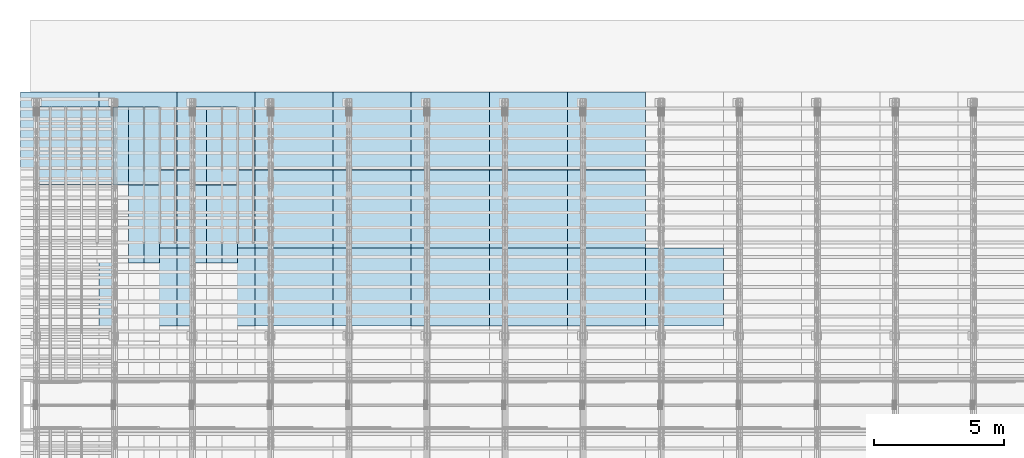
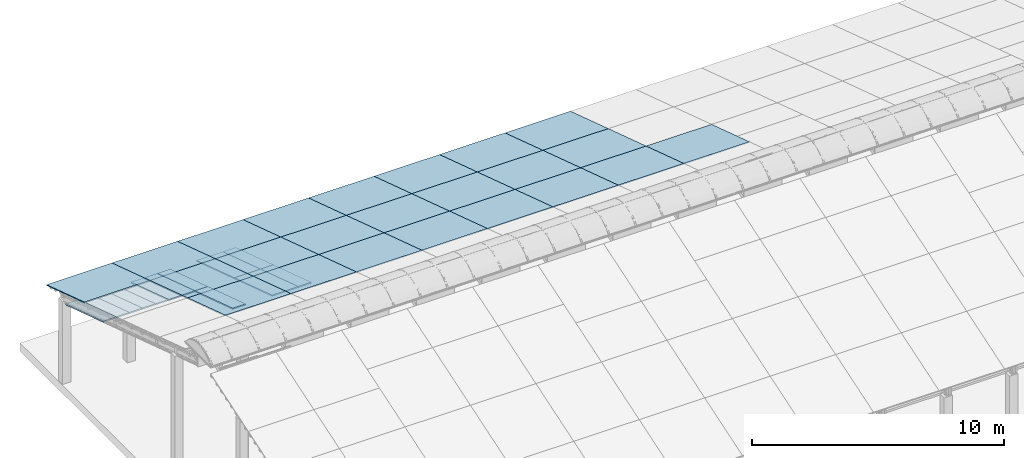
# One storey, part 8 of 385: 43 slabs, 43 elements without a shape of their own.
"""IFC2X3 building model written with IfcOpenShell, lengths in millimetres."""

from ifc_helpers import new_model, entity, si_unit, converted_unit, derived_unit, direction, frame, frame_2d, origin, place, context, subcontext, project, spatial, rectangle, extrude, material, layer, layer_set, element, aggregate, save


model = new_model("IFC2X3")

# Units and contexts
model_context = context("Model", 3, precision=0.01, world=origin(), true_north=direction((6.12303176911189e-17, 1.0)))
body_context = subcontext(model_context, "Body", "Model", "MODEL_VIEW")
ifc_project = project(units=[si_unit("LENGTHUNIT", "METRE", prefix="MILLI"), si_unit("AREAUNIT", "SQUARE_METRE"), si_unit("VOLUMEUNIT", "CUBIC_METRE"), converted_unit("PLANEANGLEUNIT", "DEGREE", entity("IfcRatioMeasure", 0.0174532925199433), si_unit("PLANEANGLEUNIT", "RADIAN"), dimensions=[0, 0, 0, 0, 0, 0, 0]), si_unit("MASSUNIT", "GRAM", prefix="KILO"), derived_unit("MASSDENSITYUNIT", [(si_unit("MASSUNIT", "GRAM", prefix="KILO"), 1), (si_unit("LENGTHUNIT", "METRE"), -3)]), si_unit("TIMEUNIT", "SECOND"), si_unit("FREQUENCYUNIT", "HERTZ"), si_unit("THERMODYNAMICTEMPERATUREUNIT", "DEGREE_CELSIUS"), derived_unit("THERMALTRANSMITTANCEUNIT", [(si_unit("MASSUNIT", "GRAM", prefix="KILO"), 1), (si_unit("THERMODYNAMICTEMPERATUREUNIT", "KELVIN"), -1), (si_unit("TIMEUNIT", "SECOND"), -3)]), derived_unit("VOLUMETRICFLOWRATEUNIT", [(si_unit("LENGTHUNIT", "METRE"), 3), (si_unit("TIMEUNIT", "SECOND"), -1)]), si_unit("ELECTRICCURRENTUNIT", "AMPERE"), si_unit("ELECTRICVOLTAGEUNIT", "VOLT"), si_unit("POWERUNIT", "WATT"), si_unit("FORCEUNIT", "NEWTON", prefix="KILO"), si_unit("ILLUMINANCEUNIT", "LUX"), si_unit("LUMINOUSFLUXUNIT", "LUMEN"), si_unit("LUMINOUSINTENSITYUNIT", "CANDELA"), derived_unit("USERDEFINED", [(si_unit("MASSUNIT", "GRAM", prefix="KILO"), -1), (si_unit("LENGTHUNIT", "METRE"), -2), (si_unit("TIMEUNIT", "SECOND"), 3), (si_unit("LUMINOUSFLUXUNIT", "LUMEN"), 1)]), derived_unit("LINEARVELOCITYUNIT", [(si_unit("LENGTHUNIT", "METRE"), 1), (si_unit("TIMEUNIT", "SECOND"), -1)]), si_unit("PRESSUREUNIT", "PASCAL"), derived_unit("USERDEFINED", [(si_unit("LENGTHUNIT", "METRE"), -2), (si_unit("MASSUNIT", "GRAM", prefix="KILO"), 1), (si_unit("TIMEUNIT", "SECOND"), -2)])], contexts=[model_context])

# Site, building, storey
site_placement = place(None, origin())
site = spatial("IfcSite", under=ifc_project, at=site_placement, CompositionType="ELEMENT")
building_placement = place(site_placement, origin())
building = spatial("IfcBuilding", under=site, at=building_placement, CompositionType="ELEMENT")
storey_placement = place(building_placement, origin())
storey = spatial("IfcBuildingStorey", under=building, at=storey_placement, Name="Default", CompositionType="ELEMENT", Elevation=0.0)

# Roof, slab
roof_1_placement = place(storey_placement, frame((-325.490958783827, 23742.4435684862, 594.897947736069)))
roof_1 = element("IfcRoof", 1, at=roof_1_placement, inside=storey, ShapeType="NOTDEFINED")
ifc_material_1 = material()
ifc_layer_1 = layer(ifc_material_1, 40.0)
ifc_layer_set_1 = layer_set([ifc_layer_1])
slab_1_placement = place(roof_1_placement, origin())
slab_1 = element("IfcSlab", 2, at=slab_1_placement, material=ifc_layer_set_1, PredefinedType="ROOF", context=body_context, shape_type="SweptSolid", body=[
    extrude(rectangle(XDim=3154.3866727148, YDim=2999.99999999999, at=frame_2d((0.0, 2.1600499167107e-12), x_axis=(0.0, 1.0))), frame((1500.0, 1500.0, 487.379544349359), z_axis=(0.0, 0.309016994374947, 0.951056516295154), x_axis=(1.0, 0.0, 0.0)), (0.0, -0.309016994374947, 0.951056516295154), 42.0584889695308),
])
aggregate(roof_1, [slab_1])

roof_2_placement = place(building_placement, frame((210.0, 23167.6676853402, -186.497271233012)))
roof_2 = element("IfcRoof", 3, at=roof_2_placement, inside=storey, ShapeType="NOTDEFINED")
ifc_material_2 = material(Name="NLRS_n7_isolatie MegaPlus_Kingspan")
ifc_layer_2 = layer(ifc_material_2, 60.0)
ifc_layer_set_2 = layer_set([ifc_layer_2])
slab_2_placement = place(roof_2_placement, origin())
slab_2 = element("IfcSlab", 4, at=slab_2_placement, material=ifc_layer_set_2, PredefinedType="ROOF", context=body_context, shape_type="SweptSolid", body=[
    extrude(rectangle(XDim=600.0, YDim=3154.38667271481, at=frame_2d((0.0, 0.0), x_axis=(-1.0, 0.0))), frame((300.0, 1500.0, 487.379544349361), z_axis=(0.0, 0.309016994374947, 0.951056516295154), x_axis=(1.0, 0.0, 0.0)), (0.0, -0.309016994374947, 0.951056516295154), 63.087733454296),
])
aggregate(roof_2, [slab_2])

roof_3_placement = place(storey_placement, frame((810.0, 23167.6676853402, -186.497271233012)))
roof_3 = element("IfcRoof", 5, at=roof_3_placement, inside=storey, ShapeType="NOTDEFINED")
slab_3_placement = place(roof_3_placement, origin())
slab_3 = element("IfcSlab", 6, at=slab_3_placement, material=ifc_layer_set_2, PredefinedType="ROOF", context=body_context, shape_type="SweptSolid", body=[
    extrude(rectangle(XDim=600.0, YDim=3154.38667271481, at=frame_2d((0.0, 0.0), x_axis=(-1.0, 0.0))), frame((300.0, 1500.0, 487.379544349361), z_axis=(0.0, 0.309016994374947, 0.951056516295154), x_axis=(1.0, 0.0, 0.0)), (0.0, -0.309016994374947, 0.951056516295154), 63.087733454296),
])
aggregate(roof_3, [slab_3])

roof_4_placement = place(storey_placement, frame((1410.0, 23167.6676853402, -186.497271233012)))
roof_4 = element("IfcRoof", 7, at=roof_4_placement, inside=storey, ShapeType="NOTDEFINED")
slab_4_placement = place(roof_4_placement, origin())
slab_4 = element("IfcSlab", 8, at=slab_4_placement, material=ifc_layer_set_2, PredefinedType="ROOF", context=body_context, shape_type="SweptSolid", body=[
    extrude(rectangle(XDim=600.0, YDim=3154.38667271481, at=frame_2d((0.0, 0.0), x_axis=(-1.0, 0.0))), frame((300.0, 1500.0, 487.379544349361), z_axis=(0.0, 0.309016994374947, 0.951056516295154), x_axis=(1.0, 0.0, 0.0)), (0.0, -0.309016994374947, 0.951056516295154), 63.087733454296),
])
aggregate(roof_4, [slab_4])

roof_5_placement = place(storey_placement, frame((2010.0, 23167.6676853402, -186.497271233012)))
roof_5 = element("IfcRoof", 9, at=roof_5_placement, inside=storey, ShapeType="NOTDEFINED")
slab_5_placement = place(roof_5_placement, origin())
slab_5 = element("IfcSlab", 10, at=slab_5_placement, material=ifc_layer_set_2, PredefinedType="ROOF", context=body_context, shape_type="SweptSolid", body=[
    extrude(rectangle(XDim=600.0, YDim=3154.38667271481, at=frame_2d((0.0, 0.0), x_axis=(-1.0, 0.0))), frame((300.0, 1500.0, 487.379544349361), z_axis=(0.0, 0.309016994374947, 0.951056516295154), x_axis=(1.0, 0.0, 0.0)), (0.0, -0.309016994374947, 0.951056516295154), 63.087733454296),
])
aggregate(roof_5, [slab_5])

roof_6_placement = place(storey_placement, frame((2610.0, 23167.6676853402, -186.497271233012)))
roof_6 = element("IfcRoof", 11, at=roof_6_placement, inside=storey, ShapeType="NOTDEFINED")
slab_6_placement = place(roof_6_placement, origin())
slab_6 = element("IfcSlab", 12, at=slab_6_placement, material=ifc_layer_set_2, PredefinedType="ROOF", context=body_context, shape_type="SweptSolid", body=[
    extrude(rectangle(XDim=600.0, YDim=3154.38667271481, at=frame_2d((0.0, 0.0), x_axis=(-1.0, 0.0))), frame((300.0, 1500.0, 487.379544349361), z_axis=(0.0, 0.309016994374947, 0.951056516295154), x_axis=(1.0, 0.0, 0.0)), (0.0, -0.309016994374947, 0.951056516295154), 63.087733454296),
])
aggregate(roof_6, [slab_6])

roof_7_placement = place(storey_placement, frame((3210.0, 23167.6676853402, -186.497271233012)))
roof_7 = element("IfcRoof", 13, at=roof_7_placement, inside=storey, ShapeType="NOTDEFINED")
slab_7_placement = place(roof_7_placement, origin())
slab_7 = element("IfcSlab", 14, at=slab_7_placement, material=ifc_layer_set_2, PredefinedType="ROOF", context=body_context, shape_type="SweptSolid", body=[
    extrude(rectangle(XDim=600.0, YDim=3154.38667271481, at=frame_2d((0.0, 0.0), x_axis=(-1.0, 0.0))), frame((300.0, 1500.0, 487.379544349361), z_axis=(0.0, 0.309016994374947, 0.951056516295154), x_axis=(1.0, 0.0, 0.0)), (0.0, -0.309016994374947, 0.951056516295154), 63.087733454296),
])
aggregate(roof_7, [slab_7])

roof_8_placement = place(storey_placement, frame((3810.0, 23167.6676853402, -186.497271233012)))
roof_8 = element("IfcRoof", 15, at=roof_8_placement, inside=storey, ShapeType="NOTDEFINED")
slab_8_placement = place(roof_8_placement, origin())
slab_8 = element("IfcSlab", 16, at=slab_8_placement, material=ifc_layer_set_2, PredefinedType="ROOF", context=body_context, shape_type="SweptSolid", body=[
    extrude(rectangle(XDim=600.0, YDim=3154.38667271481, at=frame_2d((0.0, 0.0), x_axis=(-1.0, 0.0))), frame((300.0, 1500.0, 487.379544349361), z_axis=(0.0, 0.309016994374947, 0.951056516295154), x_axis=(1.0, 0.0, 0.0)), (0.0, -0.309016994374947, 0.951056516295154), 63.087733454296),
])
aggregate(roof_8, [slab_8])

roof_9_placement = place(storey_placement, frame((4410.0, 23167.6676853402, -186.497271233012)))
roof_9 = element("IfcRoof", 17, at=roof_9_placement, inside=storey, ShapeType="NOTDEFINED")
slab_9_placement = place(roof_9_placement, origin())
slab_9 = element("IfcSlab", 18, at=slab_9_placement, material=ifc_layer_set_2, PredefinedType="ROOF", context=body_context, shape_type="SweptSolid", body=[
    extrude(rectangle(XDim=600.0, YDim=3154.38667271481, at=frame_2d((0.0, 0.0), x_axis=(-1.0, 0.0))), frame((300.0, 1500.0, 487.379544349361), z_axis=(0.0, 0.309016994374947, 0.951056516295154), x_axis=(1.0, 0.0, 0.0)), (0.0, -0.309016994374947, 0.951056516295154), 63.087733454296),
])
aggregate(roof_9, [slab_9])

roof_10_placement = place(storey_placement, frame((4410.0, 20167.6676853402, 788.261817465712)))
roof_10 = element("IfcRoof", 19, at=roof_10_placement, inside=storey, ShapeType="NOTDEFINED")
slab_10_placement = place(roof_10_placement, origin())
slab_10 = element("IfcSlab", 20, at=slab_10_placement, material=ifc_layer_set_2, PredefinedType="ROOF", context=body_context, shape_type="SweptSolid", body=[
    extrude(rectangle(XDim=600.000000000001, YDim=3154.38667271481, at=frame_2d((-2.8421709430404e-13, 0.0), x_axis=(-1.0, 0.0))), frame((300.0, 1500.0, 487.379544349361), z_axis=(0.0, 0.309016994374947, 0.951056516295154), x_axis=(1.0, 0.0, 0.0)), (0.0, -0.309016994374947, 0.951056516295154), 63.087733454296),
])
aggregate(roof_10, [slab_10])

roof_11_placement = place(storey_placement, frame((3210.0, 23167.6676853402, -186.497271233012)))
roof_11 = element("IfcRoof", 21, at=roof_11_placement, inside=storey, ShapeType="NOTDEFINED")
slab_11_placement = place(roof_11_placement, origin())
slab_11 = element("IfcSlab", 22, at=slab_11_placement, material=ifc_layer_set_2, PredefinedType="ROOF", context=body_context, shape_type="SweptSolid", body=[
    extrude(rectangle(XDim=600.0, YDim=3154.38667271481, at=frame_2d((0.0, 0.0), x_axis=(-1.0, 0.0))), frame((300.0, 1500.0, 487.379544349361), z_axis=(0.0, 0.309016994374947, 0.951056516295154), x_axis=(1.0, 0.0, 0.0)), (0.0, -0.309016994374947, 0.951056516295154), 63.087733454296),
])
aggregate(roof_11, [slab_11])

roof_12_placement = place(storey_placement, frame((3810.0, 23167.6676853402, -186.497271233012)))
roof_12 = element("IfcRoof", 23, at=roof_12_placement, inside=storey, ShapeType="NOTDEFINED")
slab_12_placement = place(roof_12_placement, origin())
slab_12 = element("IfcSlab", 24, at=slab_12_placement, material=ifc_layer_set_2, PredefinedType="ROOF", context=body_context, shape_type="SweptSolid", body=[
    extrude(rectangle(XDim=600.0, YDim=3154.38667271481, at=frame_2d((0.0, 0.0), x_axis=(-1.0, 0.0))), frame((300.0, 1500.0, 487.379544349361), z_axis=(0.0, 0.309016994374947, 0.951056516295154), x_axis=(1.0, 0.0, 0.0)), (0.0, -0.309016994374947, 0.951056516295154), 63.087733454296),
])
aggregate(roof_12, [slab_12])

roof_13_placement = place(storey_placement, frame((3810.0, 20167.6676853402, 788.261817465712)))
roof_13 = element("IfcRoof", 25, at=roof_13_placement, inside=storey, ShapeType="NOTDEFINED")
slab_13_placement = place(roof_13_placement, origin())
slab_13 = element("IfcSlab", 26, at=slab_13_placement, material=ifc_layer_set_2, PredefinedType="ROOF", context=body_context, shape_type="SweptSolid", body=[
    extrude(rectangle(XDim=600.0, YDim=3154.38667271481, at=frame_2d((0.0, 0.0), x_axis=(-1.0, 0.0))), frame((300.0, 1500.0, 487.379544349361), z_axis=(0.0, 0.309016994374947, 0.951056516295154), x_axis=(1.0, 0.0, 0.0)), (0.0, -0.309016994374947, 0.951056516295154), 63.087733454296),
])
aggregate(roof_13, [slab_13])

roof_14_placement = place(storey_placement, frame((4410.0, 23167.6676853402, -186.497271233012)))
roof_14 = element("IfcRoof", 27, at=roof_14_placement, inside=storey, ShapeType="NOTDEFINED")
slab_14_placement = place(roof_14_placement, origin())
slab_14 = element("IfcSlab", 28, at=slab_14_placement, material=ifc_layer_set_2, PredefinedType="ROOF", context=body_context, shape_type="SweptSolid", body=[
    extrude(rectangle(XDim=600.000000000001, YDim=3154.38667271481, at=frame_2d((-2.8421709430404e-13, 0.0), x_axis=(-1.0, 0.0))), frame((300.0, 1500.0, 487.379544349361), z_axis=(0.0, 0.309016994374947, 0.951056516295154), x_axis=(1.0, 0.0, 0.0)), (0.0, -0.309016994374947, 0.951056516295154), 63.087733454296),
])
aggregate(roof_14, [slab_14])

roof_15_placement = place(storey_placement, frame((4410.0, 20167.6676853402, 788.261817465712)))
roof_15 = element("IfcRoof", 29, at=roof_15_placement, inside=storey, ShapeType="NOTDEFINED")
slab_15_placement = place(roof_15_placement, origin())
slab_15 = element("IfcSlab", 30, at=slab_15_placement, material=ifc_layer_set_2, PredefinedType="ROOF", context=body_context, shape_type="SweptSolid", body=[
    extrude(rectangle(XDim=600.0, YDim=3154.38667271481, at=frame_2d((0.0, 0.0), x_axis=(-1.0, 0.0))), frame((300.0, 1500.0, 487.379544349361), z_axis=(0.0, 0.309016994374947, 0.951056516295154), x_axis=(1.0, 0.0, 0.0)), (0.0, -0.309016994374947, 0.951056516295154), 63.087733454296),
])
aggregate(roof_15, [slab_15])

roof_16_placement = place(storey_placement, frame((6210.0, 23167.6676853402, -186.497271233012)))
roof_16 = element("IfcRoof", 31, at=roof_16_placement, inside=storey, ShapeType="NOTDEFINED")
slab_16_placement = place(roof_16_placement, origin())
slab_16 = element("IfcSlab", 32, at=slab_16_placement, material=ifc_layer_set_2, PredefinedType="ROOF", context=body_context, shape_type="SweptSolid", body=[
    extrude(rectangle(XDim=600.0, YDim=3154.38667271481, at=frame_2d((0.0, 0.0), x_axis=(-1.0, 0.0))), frame((300.0, 1500.0, 487.379544349361), z_axis=(0.0, 0.309016994374947, 0.951056516295154), x_axis=(1.0, 0.0, 0.0)), (0.0, -0.309016994374947, 0.951056516295154), 63.087733454296),
])
aggregate(roof_16, [slab_16])

roof_17_placement = place(storey_placement, frame((6210.0, 20167.6676853402, 788.261817465712)))
roof_17 = element("IfcRoof", 33, at=roof_17_placement, inside=storey, ShapeType="NOTDEFINED")
slab_17_placement = place(roof_17_placement, origin())
slab_17 = element("IfcSlab", 34, at=slab_17_placement, material=ifc_layer_set_2, PredefinedType="ROOF", context=body_context, shape_type="SweptSolid", body=[
    extrude(rectangle(XDim=600.0, YDim=3154.38667271481, at=frame_2d((0.0, 0.0), x_axis=(-1.0, 0.0))), frame((300.0, 1500.0, 487.379544349361), z_axis=(0.0, 0.309016994374947, 0.951056516295154), x_axis=(1.0, 0.0, 0.0)), (0.0, -0.309016994374947, 0.951056516295154), 63.087733454296),
])
aggregate(roof_17, [slab_17])

roof_18_placement = place(storey_placement, frame((6810.0, 23167.6676853402, -186.497271233012)))
roof_18 = element("IfcRoof", 35, at=roof_18_placement, inside=storey, ShapeType="NOTDEFINED")
slab_18_placement = place(roof_18_placement, origin())
slab_18 = element("IfcSlab", 36, at=slab_18_placement, material=ifc_layer_set_2, PredefinedType="ROOF", context=body_context, shape_type="SweptSolid", body=[
    extrude(rectangle(XDim=600.0, YDim=3154.38667271481, at=frame_2d((0.0, 0.0), x_axis=(-1.0, 0.0))), frame((300.0, 1500.0, 487.379544349361), z_axis=(0.0, 0.309016994374947, 0.951056516295154), x_axis=(1.0, 0.0, 0.0)), (0.0, -0.309016994374947, 0.951056516295154), 63.087733454296),
])
aggregate(roof_18, [slab_18])

roof_19_placement = place(storey_placement, frame((6810.0, 20167.6676853402, 788.261817465712)))
roof_19 = element("IfcRoof", 37, at=roof_19_placement, inside=storey, ShapeType="NOTDEFINED")
slab_19_placement = place(roof_19_placement, origin())
slab_19 = element("IfcSlab", 38, at=slab_19_placement, material=ifc_layer_set_2, PredefinedType="ROOF", context=body_context, shape_type="SweptSolid", body=[
    extrude(rectangle(XDim=600.0, YDim=3154.38667271481, at=frame_2d((0.0, 0.0), x_axis=(-1.0, 0.0))), frame((300.0, 1500.0, 487.379544349361), z_axis=(0.0, 0.309016994374947, 0.951056516295154), x_axis=(1.0, 0.0, 0.0)), (0.0, -0.309016994374947, 0.951056516295154), 63.087733454296),
])
aggregate(roof_19, [slab_19])

roof_20_placement = place(storey_placement, frame((7410.0, 23167.6676853402, -186.497271233012)))
roof_20 = element("IfcRoof", 39, at=roof_20_placement, inside=storey, ShapeType="NOTDEFINED")
slab_20_placement = place(roof_20_placement, origin())
slab_20 = element("IfcSlab", 40, at=slab_20_placement, material=ifc_layer_set_2, PredefinedType="ROOF", context=body_context, shape_type="SweptSolid", body=[
    extrude(rectangle(XDim=600.0, YDim=3154.38667271481, at=frame_2d((0.0, 0.0), x_axis=(-1.0, 0.0))), frame((300.0, 1500.0, 487.379544349361), z_axis=(0.0, 0.309016994374947, 0.951056516295154), x_axis=(1.0, 0.0, 0.0)), (0.0, -0.309016994374947, 0.951056516295154), 63.087733454296),
])
aggregate(roof_20, [slab_20])

roof_21_placement = place(storey_placement, frame((7410.0, 20167.6676853402, 788.261817465712)))
roof_21 = element("IfcRoof", 41, at=roof_21_placement, inside=storey, ShapeType="NOTDEFINED")
slab_21_placement = place(roof_21_placement, origin())
slab_21 = element("IfcSlab", 42, at=slab_21_placement, material=ifc_layer_set_2, PredefinedType="ROOF", context=body_context, shape_type="SweptSolid", body=[
    extrude(rectangle(XDim=600.0, YDim=3154.38667271481, at=frame_2d((0.0, 0.0), x_axis=(-1.0, 0.0))), frame((300.0, 1500.0, 487.379544349361), z_axis=(0.0, 0.309016994374947, 0.951056516295154), x_axis=(1.0, 0.0, 0.0)), (0.0, -0.309016994374947, 0.951056516295154), 63.087733454296),
])
aggregate(roof_21, [slab_21])

roof_22_placement = place(storey_placement, frame((2674.50904121616, 23742.4435684862, 594.897947736069)))
roof_22 = element("IfcRoof", 43, at=roof_22_placement, inside=storey, ShapeType="NOTDEFINED")
slab_22_placement = place(roof_22_placement, origin())
slab_22 = element("IfcSlab", 44, at=slab_22_placement, material=ifc_layer_set_1, PredefinedType="ROOF", context=body_context, shape_type="SweptSolid", body=[
    extrude(rectangle(XDim=3154.3866727148, YDim=2999.99999999999, at=frame_2d((0.0, 2.1600499167107e-12), x_axis=(0.0, 1.0))), frame((1500.0, 1500.0, 487.379544349359), z_axis=(0.0, 0.309016994374947, 0.951056516295154), x_axis=(1.0, 0.0, 0.0)), (0.0, -0.309016994374947, 0.951056516295154), 42.0584889695308),
])
aggregate(roof_22, [slab_22])

roof_23_placement = place(storey_placement, frame((2674.50904121616, 20742.4435684862, 1569.65703643478)))
roof_23 = element("IfcRoof", 45, at=roof_23_placement, inside=storey, ShapeType="NOTDEFINED")
slab_23_placement = place(roof_23_placement, origin())
slab_23 = element("IfcSlab", 46, at=slab_23_placement, material=ifc_layer_set_1, PredefinedType="ROOF", context=body_context, shape_type="SweptSolid", body=[
    extrude(rectangle(XDim=3154.3866727148, YDim=2999.99999999999, at=frame_2d((-4.54747350886464e-13, 1.13686837721616e-13), x_axis=(0.0, 1.0))), frame((1500.0, 1500.0, 487.379544349359), z_axis=(0.0, 0.309016994374947, 0.951056516295154), x_axis=(1.0, 0.0, 0.0)), (0.0, -0.309016994374947, 0.951056516295154), 42.0584889695308),
])
aggregate(roof_23, [slab_23])

roof_24_placement = place(storey_placement, frame((2674.50904121615, 17742.4435684862, 2544.4161251335)))
roof_24 = element("IfcRoof", 47, at=roof_24_placement, inside=storey, ShapeType="NOTDEFINED")
slab_24_placement = place(roof_24_placement, origin())
slab_24 = element("IfcSlab", 48, at=slab_24_placement, material=ifc_layer_set_1, PredefinedType="ROOF", context=body_context, shape_type="SweptSolid", body=[
    extrude(rectangle(XDim=3154.3866727148, YDim=2999.99999999999, at=frame_2d((-1.02318153949454e-12, 1.13686837721616e-12), x_axis=(0.0, 1.0))), frame((1500.0, 1500.0, 487.379544349359), z_axis=(0.0, 0.309016994374947, 0.951056516295154), x_axis=(1.0, 0.0, 0.0)), (0.0, -0.309016994374947, 0.951056516295154), 42.0584889695308),
])
aggregate(roof_24, [slab_24])

roof_25_placement = place(storey_placement, frame((5674.50904121616, 23742.4435684862, 594.897947736069)))
roof_25 = element("IfcRoof", 49, at=roof_25_placement, inside=storey, ShapeType="NOTDEFINED")
slab_25_placement = place(roof_25_placement, origin())
slab_25 = element("IfcSlab", 50, at=slab_25_placement, material=ifc_layer_set_1, PredefinedType="ROOF", context=body_context, shape_type="SweptSolid", body=[
    extrude(rectangle(XDim=3154.3866727148, YDim=2999.99999999999, at=frame_2d((0.0, 2.1600499167107e-12), x_axis=(0.0, 1.0))), frame((1500.0, 1500.0, 487.379544349359), z_axis=(0.0, 0.309016994374947, 0.951056516295154), x_axis=(1.0, 0.0, 0.0)), (0.0, -0.309016994374947, 0.951056516295154), 42.0584889695308),
])
aggregate(roof_25, [slab_25])

roof_26_placement = place(storey_placement, frame((5674.50904121615, 20742.4435684861, 1569.65703643478)))
roof_26 = element("IfcRoof", 51, at=roof_26_placement, inside=storey, ShapeType="NOTDEFINED")
slab_26_placement = place(roof_26_placement, origin())
slab_26 = element("IfcSlab", 52, at=slab_26_placement, material=ifc_layer_set_1, PredefinedType="ROOF", context=body_context, shape_type="SweptSolid", body=[
    extrude(rectangle(XDim=3154.3866727148, YDim=2999.99999999999, at=frame_2d((-4.54747350886464e-13, 1.13686837721616e-13), x_axis=(0.0, 1.0))), frame((1500.0, 1500.0, 487.379544349359), z_axis=(0.0, 0.309016994374947, 0.951056516295154), x_axis=(1.0, 0.0, 0.0)), (0.0, -0.309016994374947, 0.951056516295154), 42.0584889695308),
])
aggregate(roof_26, [slab_26])

roof_27_placement = place(storey_placement, frame((5674.50904121614, 17742.4435684861, 2544.4161251335)))
roof_27 = element("IfcRoof", 53, at=roof_27_placement, inside=storey, ShapeType="NOTDEFINED")
slab_27_placement = place(roof_27_placement, origin())
slab_27 = element("IfcSlab", 54, at=slab_27_placement, material=ifc_layer_set_1, PredefinedType="ROOF", context=body_context, shape_type="SweptSolid", body=[
    extrude(rectangle(XDim=3154.3866727148, YDim=2999.99999999999, at=frame_2d((-1.02318153949454e-12, 1.13686837721616e-12), x_axis=(0.0, 1.0))), frame((1500.0, 1500.0, 487.379544349359), z_axis=(0.0, 0.309016994374947, 0.951056516295154), x_axis=(1.0, 0.0, 0.0)), (0.0, -0.309016994374947, 0.951056516295154), 42.0584889695308),
])
aggregate(roof_27, [slab_27])

roof_28_placement = place(storey_placement, frame((8674.50904121615, 23742.4435684861, 594.897947736069)))
roof_28 = element("IfcRoof", 55, at=roof_28_placement, inside=storey, ShapeType="NOTDEFINED")
slab_28_placement = place(roof_28_placement, origin())
slab_28 = element("IfcSlab", 56, at=slab_28_placement, material=ifc_layer_set_1, PredefinedType="ROOF", context=body_context, shape_type="SweptSolid", body=[
    extrude(rectangle(XDim=3154.3866727148, YDim=2999.99999999999, at=frame_2d((0.0, 2.1600499167107e-12), x_axis=(0.0, 1.0))), frame((1500.0, 1500.0, 487.379544349359), z_axis=(0.0, 0.309016994374947, 0.951056516295154), x_axis=(1.0, 0.0, 0.0)), (0.0, -0.309016994374947, 0.951056516295154), 42.0584889695308),
])
aggregate(roof_28, [slab_28])

roof_29_placement = place(storey_placement, frame((8674.50904121615, 20742.4435684861, 1569.65703643478)))
roof_29 = element("IfcRoof", 57, at=roof_29_placement, inside=storey, ShapeType="NOTDEFINED")
slab_29_placement = place(roof_29_placement, origin())
slab_29 = element("IfcSlab", 58, at=slab_29_placement, material=ifc_layer_set_1, PredefinedType="ROOF", context=body_context, shape_type="SweptSolid", body=[
    extrude(rectangle(XDim=3154.3866727148, YDim=2999.99999999999, at=frame_2d((-4.54747350886464e-13, 1.13686837721616e-13), x_axis=(0.0, 1.0))), frame((1500.0, 1500.0, 487.379544349359), z_axis=(0.0, 0.309016994374947, 0.951056516295154), x_axis=(1.0, 0.0, 0.0)), (0.0, -0.309016994374947, 0.951056516295154), 42.0584889695308),
])
aggregate(roof_29, [slab_29])

roof_30_placement = place(storey_placement, frame((8674.50904121613, 17742.4435684861, 2544.4161251335)))
roof_30 = element("IfcRoof", 59, at=roof_30_placement, inside=storey, ShapeType="NOTDEFINED")
slab_30_placement = place(roof_30_placement, origin())
slab_30 = element("IfcSlab", 60, at=slab_30_placement, material=ifc_layer_set_1, PredefinedType="ROOF", context=body_context, shape_type="SweptSolid", body=[
    extrude(rectangle(XDim=3154.3866727148, YDim=2999.99999999999, at=frame_2d((1.02318153949454e-12, 1.13686837721616e-12), x_axis=(0.0, 1.0))), frame((1500.0, 1500.0, 487.379544349359), z_axis=(0.0, 0.309016994374947, 0.951056516295154), x_axis=(1.0, 0.0, 0.0)), (0.0, -0.309016994374947, 0.951056516295154), 42.0584889695308),
])
aggregate(roof_30, [slab_30])

roof_31_placement = place(storey_placement, frame((11674.5090412161, 23742.4435684861, 594.897947736069)))
roof_31 = element("IfcRoof", 61, at=roof_31_placement, inside=storey, ShapeType="NOTDEFINED")
slab_31_placement = place(roof_31_placement, origin())
slab_31 = element("IfcSlab", 62, at=slab_31_placement, material=ifc_layer_set_1, PredefinedType="ROOF", context=body_context, shape_type="SweptSolid", body=[
    extrude(rectangle(XDim=3154.3866727148, YDim=2999.99999999999, at=frame_2d((0.0, 2.1600499167107e-12), x_axis=(0.0, 1.0))), frame((1500.0, 1500.0, 487.379544349359), z_axis=(0.0, 0.309016994374947, 0.951056516295154), x_axis=(1.0, 0.0, 0.0)), (0.0, -0.309016994374947, 0.951056516295154), 42.0584889695308),
])
aggregate(roof_31, [slab_31])

roof_32_placement = place(storey_placement, frame((11674.5090412161, 20742.4435684861, 1569.65703643478)))
roof_32 = element("IfcRoof", 63, at=roof_32_placement, inside=storey, ShapeType="NOTDEFINED")
slab_32_placement = place(roof_32_placement, origin())
slab_32 = element("IfcSlab", 64, at=slab_32_placement, material=ifc_layer_set_1, PredefinedType="ROOF", context=body_context, shape_type="SweptSolid", body=[
    extrude(rectangle(XDim=3154.3866727148, YDim=2999.99999999999, at=frame_2d((1.02318153949454e-12, 1.13686837721616e-13), x_axis=(0.0, 1.0))), frame((1500.0, 1500.0, 487.379544349359), z_axis=(0.0, 0.309016994374947, 0.951056516295154), x_axis=(1.0, 0.0, 0.0)), (0.0, -0.309016994374947, 0.951056516295154), 42.0584889695308),
])
aggregate(roof_32, [slab_32])

roof_33_placement = place(storey_placement, frame((11674.5090412161, 17742.4435684861, 2544.4161251335)))
roof_33 = element("IfcRoof", 65, at=roof_33_placement, inside=storey, ShapeType="NOTDEFINED")
slab_33_placement = place(roof_33_placement, origin())
slab_33 = element("IfcSlab", 66, at=slab_33_placement, material=ifc_layer_set_1, PredefinedType="ROOF", context=body_context, shape_type="SweptSolid", body=[
    extrude(rectangle(XDim=3154.3866727148, YDim=2999.99999999999, at=frame_2d((0.0, 1.13686837721616e-12), x_axis=(0.0, 1.0))), frame((1500.0, 1500.0, 487.379544349359), z_axis=(0.0, 0.309016994374947, 0.951056516295154), x_axis=(1.0, 0.0, 0.0)), (0.0, -0.309016994374947, 0.951056516295154), 42.0584889695308),
])
aggregate(roof_33, [slab_33])

roof_34_placement = place(storey_placement, frame((14674.5090412161, 23742.4435684861, 594.897947736069)))
roof_34 = element("IfcRoof", 67, at=roof_34_placement, inside=storey, ShapeType="NOTDEFINED")
slab_34_placement = place(roof_34_placement, origin())
slab_34 = element("IfcSlab", 68, at=slab_34_placement, material=ifc_layer_set_1, PredefinedType="ROOF", context=body_context, shape_type="SweptSolid", body=[
    extrude(rectangle(XDim=3154.3866727148, YDim=2999.99999999999, at=frame_2d((0.0, 2.1600499167107e-12), x_axis=(0.0, 1.0))), frame((1500.0, 1500.0, 487.379544349359), z_axis=(0.0, 0.309016994374947, 0.951056516295154), x_axis=(1.0, 0.0, 0.0)), (0.0, -0.309016994374947, 0.951056516295154), 42.0584889695308),
])
aggregate(roof_34, [slab_34])

roof_35_placement = place(storey_placement, frame((14674.5090412161, 20742.4435684861, 1569.65703643478)))
roof_35 = element("IfcRoof", 69, at=roof_35_placement, inside=storey, ShapeType="NOTDEFINED")
slab_35_placement = place(roof_35_placement, origin())
slab_35 = element("IfcSlab", 70, at=slab_35_placement, material=ifc_layer_set_1, PredefinedType="ROOF", context=body_context, shape_type="SweptSolid", body=[
    extrude(rectangle(XDim=3154.3866727148, YDim=2999.99999999999, at=frame_2d((1.02318153949454e-12, 1.13686837721616e-13), x_axis=(0.0, 1.0))), frame((1500.0, 1500.0, 487.379544349359), z_axis=(0.0, 0.309016994374947, 0.951056516295154), x_axis=(1.0, 0.0, 0.0)), (0.0, -0.309016994374947, 0.951056516295154), 42.0584889695308),
])
aggregate(roof_35, [slab_35])

roof_36_placement = place(storey_placement, frame((14674.5090412161, 17742.4435684861, 2544.4161251335)))
roof_36 = element("IfcRoof", 71, at=roof_36_placement, inside=storey, ShapeType="NOTDEFINED")
slab_36_placement = place(roof_36_placement, origin())
slab_36 = element("IfcSlab", 72, at=slab_36_placement, material=ifc_layer_set_1, PredefinedType="ROOF", context=body_context, shape_type="SweptSolid", body=[
    extrude(rectangle(XDim=3154.3866727148, YDim=2999.99999999999, at=frame_2d((0.0, 1.13686837721616e-12), x_axis=(0.0, 1.0))), frame((1500.0, 1500.0, 487.379544349359), z_axis=(0.0, 0.309016994374947, 0.951056516295154), x_axis=(1.0, 0.0, 0.0)), (0.0, -0.309016994374947, 0.951056516295154), 42.0584889695308),
])
aggregate(roof_36, [slab_36])

roof_37_placement = place(storey_placement, frame((17674.5090412161, 23742.4435684861, 594.897947736069)))
roof_37 = element("IfcRoof", 73, at=roof_37_placement, inside=storey, ShapeType="NOTDEFINED")
slab_37_placement = place(roof_37_placement, origin())
slab_37 = element("IfcSlab", 74, at=slab_37_placement, material=ifc_layer_set_1, PredefinedType="ROOF", context=body_context, shape_type="SweptSolid", body=[
    extrude(rectangle(XDim=3154.3866727148, YDim=2999.99999999999, at=frame_2d((0.0, 2.1600499167107e-12), x_axis=(0.0, 1.0))), frame((1500.0, 1500.0, 487.379544349359), z_axis=(0.0, 0.309016994374947, 0.951056516295154), x_axis=(1.0, 0.0, 0.0)), (0.0, -0.309016994374947, 0.951056516295154), 42.0584889695308),
])
aggregate(roof_37, [slab_37])

roof_38_placement = place(storey_placement, frame((17674.5090412161, 20742.4435684861, 1569.65703643478)))
roof_38 = element("IfcRoof", 75, at=roof_38_placement, inside=storey, ShapeType="NOTDEFINED")
slab_38_placement = place(roof_38_placement, origin())
slab_38 = element("IfcSlab", 76, at=slab_38_placement, material=ifc_layer_set_1, PredefinedType="ROOF", context=body_context, shape_type="SweptSolid", body=[
    extrude(rectangle(XDim=3154.3866727148, YDim=2999.99999999999, at=frame_2d((1.02318153949454e-12, 1.13686837721616e-13), x_axis=(0.0, 1.0))), frame((1500.0, 1500.0, 487.379544349359), z_axis=(0.0, 0.309016994374947, 0.951056516295154), x_axis=(1.0, 0.0, 0.0)), (0.0, -0.309016994374947, 0.951056516295154), 42.0584889695308),
])
aggregate(roof_38, [slab_38])

roof_39_placement = place(storey_placement, frame((17674.5090412161, 17742.4435684861, 2544.4161251335)))
roof_39 = element("IfcRoof", 77, at=roof_39_placement, inside=storey, ShapeType="NOTDEFINED")
slab_39_placement = place(roof_39_placement, origin())
slab_39 = element("IfcSlab", 78, at=slab_39_placement, material=ifc_layer_set_1, PredefinedType="ROOF", context=body_context, shape_type="SweptSolid", body=[
    extrude(rectangle(XDim=3154.3866727148, YDim=2999.99999999999, at=frame_2d((0.0, 1.13686837721616e-12), x_axis=(0.0, 1.0))), frame((1500.0, 1500.0, 487.379544349359), z_axis=(0.0, 0.309016994374947, 0.951056516295154), x_axis=(1.0, 0.0, 0.0)), (0.0, -0.309016994374947, 0.951056516295154), 42.0584889695308),
])
aggregate(roof_39, [slab_39])

roof_40_placement = place(storey_placement, frame((20674.5090412161, 23742.4435684861, 594.897947736069)))
roof_40 = element("IfcRoof", 79, at=roof_40_placement, inside=storey, ShapeType="NOTDEFINED")
slab_40_placement = place(roof_40_placement, origin())
slab_40 = element("IfcSlab", 80, at=slab_40_placement, material=ifc_layer_set_1, PredefinedType="ROOF", context=body_context, shape_type="SweptSolid", body=[
    extrude(rectangle(XDim=3154.3866727148, YDim=2999.99999999999, at=frame_2d((0.0, 2.1600499167107e-12), x_axis=(0.0, 1.0))), frame((1500.0, 1500.0, 487.379544349359), z_axis=(0.0, 0.309016994374947, 0.951056516295154), x_axis=(1.0, 0.0, 0.0)), (0.0, -0.309016994374947, 0.951056516295154), 42.0584889695308),
])
aggregate(roof_40, [slab_40])

roof_41_placement = place(storey_placement, frame((20674.5090412161, 20742.4435684861, 1569.65703643478)))
roof_41 = element("IfcRoof", 81, at=roof_41_placement, inside=storey, ShapeType="NOTDEFINED")
slab_41_placement = place(roof_41_placement, origin())
slab_41 = element("IfcSlab", 82, at=slab_41_placement, material=ifc_layer_set_1, PredefinedType="ROOF", context=body_context, shape_type="SweptSolid", body=[
    extrude(rectangle(XDim=3154.3866727148, YDim=2999.99999999999, at=frame_2d((-2.1600499167107e-12, 1.13686837721616e-13), x_axis=(0.0, 1.0))), frame((1500.0, 1500.0, 487.379544349359), z_axis=(0.0, 0.309016994374947, 0.951056516295154), x_axis=(1.0, 0.0, 0.0)), (0.0, -0.309016994374947, 0.951056516295154), 42.0584889695308),
])
aggregate(roof_41, [slab_41])

roof_42_placement = place(storey_placement, frame((20674.5090412161, 17742.4435684861, 2544.4161251335)))
roof_42 = element("IfcRoof", 83, at=roof_42_placement, inside=storey, ShapeType="NOTDEFINED")
slab_42_placement = place(roof_42_placement, origin())
slab_42 = element("IfcSlab", 84, at=slab_42_placement, material=ifc_layer_set_1, PredefinedType="ROOF", context=body_context, shape_type="SweptSolid", body=[
    extrude(rectangle(XDim=3154.3866727148, YDim=2999.99999999999, at=frame_2d((0.0, 1.13686837721616e-12), x_axis=(0.0, 1.0))), frame((1500.0, 1500.0, 487.379544349359), z_axis=(0.0, 0.309016994374947, 0.951056516295154), x_axis=(1.0, 0.0, 0.0)), (0.0, -0.309016994374947, 0.951056516295154), 42.0584889695308),
])
aggregate(roof_42, [slab_42])

roof_43_placement = place(storey_placement, frame((23674.5090412161, 17742.4435684861, 2544.4161251335)))
roof_43 = element("IfcRoof", 85, at=roof_43_placement, inside=storey, ShapeType="NOTDEFINED")
slab_43_placement = place(roof_43_placement, origin())
slab_43 = element("IfcSlab", 86, at=slab_43_placement, material=ifc_layer_set_1, PredefinedType="ROOF", context=body_context, shape_type="SweptSolid", body=[
    extrude(rectangle(XDim=3154.3866727148, YDim=2999.99999999999, at=frame_2d((0.0, 1.13686837721616e-12), x_axis=(0.0, 1.0))), frame((1500.0, 1500.0, 487.379544349359), z_axis=(0.0, 0.309016994374947, 0.951056516295154), x_axis=(1.0, 0.0, 0.0)), (0.0, -0.309016994374947, 0.951056516295154), 42.0584889695308),
])
aggregate(roof_43, [slab_43])

save(model, "model.ifc")
